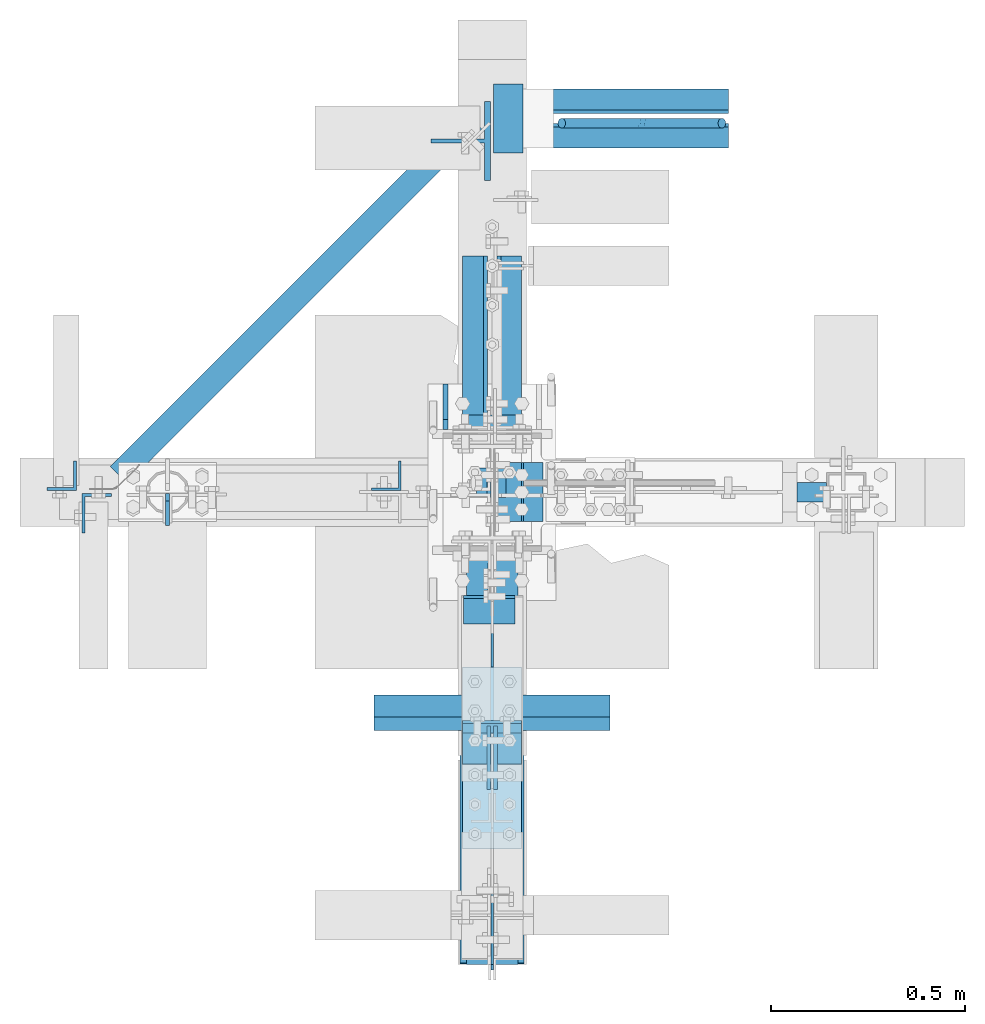
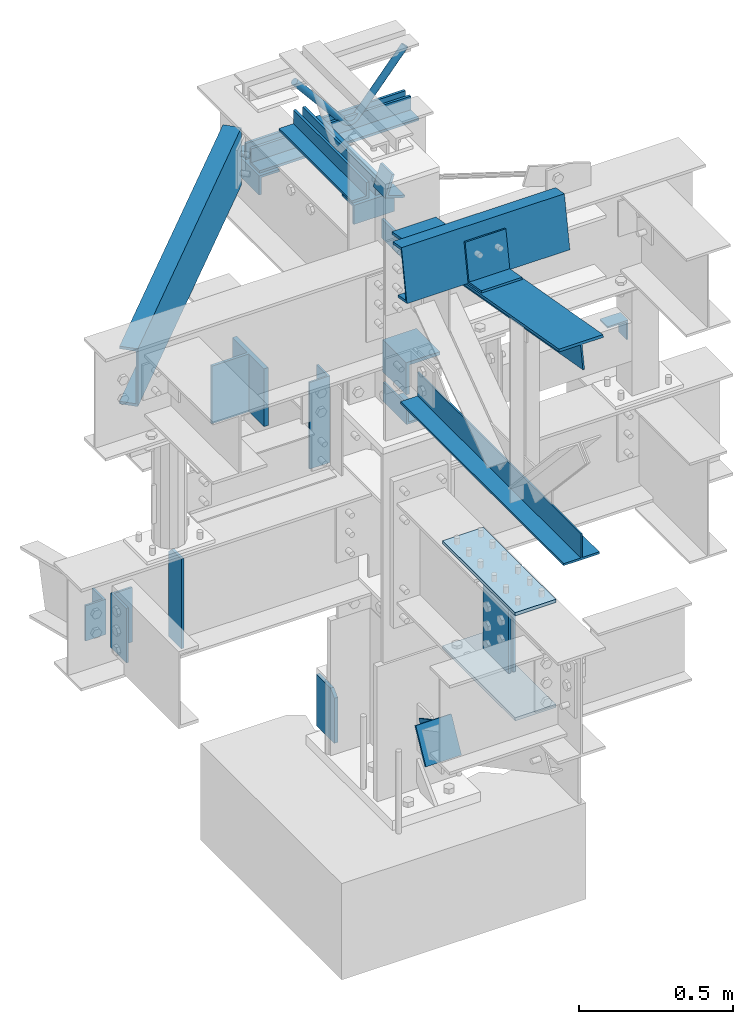
# Not in any storey, part 2 of 8: 19 members, 6 plates, 3 beams, 17 elements without a shape of their own.
"""IFC2X3 building model written with IfcOpenShell, lengths in inches."""

from ifc_helpers import new_model, entity, si_unit, converted_unit, frame, origin_with_axes, place, context, project, spatial, faceted_brep, source, transform, mapped, material, type_object, type_shapes, element, aggregate, save


model = new_model("IFC2X3")

# Units and contexts
model_context = context("Model", 3, precision=1e-05, world=origin_with_axes())
ifc_project = project(units=[converted_unit("LENGTHUNIT", "INCH", entity("IfcLengthMeasure", 25.4), si_unit("LENGTHUNIT", "METRE", prefix="MILLI"), dimensions=[1, 0, 0, 0, 0, 0, 0]), si_unit("PLANEANGLEUNIT", "RADIAN"), si_unit("MASSUNIT", "GRAM", prefix="KILO"), si_unit("TIMEUNIT", "SECOND"), si_unit("AREAUNIT", "SQUARE_METRE"), si_unit("PRESSUREUNIT", "PASCAL"), si_unit("FORCEUNIT", "NEWTON"), si_unit("THERMODYNAMICTEMPERATUREUNIT", "DEGREE_CELSIUS")], contexts=[model_context])

# Site, building
site_placement = place(None, origin_with_axes())
site = spatial("IfcSite", under=ifc_project, at=site_placement, CompositionType="ELEMENT")
building_placement = place(site_placement, origin_with_axes())
building = spatial("IfcBuilding", under=site, at=building_placement, Name="Building", CompositionType="ELEMENT")

# Assembly, members
assembly_1_placement = place(building_placement, frame((0.0, 0.0, 97.0), z_axis=(0.0, 0.0, -1.0), x_axis=(0.0, 1.0, 0.0)))
assembly_1 = element("IfcElementAssembly", 1, at=assembly_1_placement, inside=building, Name="M_40", PredefinedType="NOTDEFINED")
ifc_material_1 = material()
member_type_1 = type_object("IfcMemberType", Name="L2-1/2x2-1/2x3/8", PredefinedType="USERDEFINED", material=ifc_material_1)
shared_shape_1 = source(origin_with_axes(), model_context, "Body", "Brep", [
    faceted_brep([(0.0, 0.0, 0.0), (0.0, -2.5, 0.0), (0.0, -2.5, 0.375), (0.0, -0.375, 0.375), (0.0, -0.375, 2.5), (0.0, 0.0, 2.5), (18.625, 0.0, 2.5), (18.625, -0.375, 2.5), (18.625, -0.375, 0.375), (18.625, -2.5, 0.375), (18.625, -2.5, 0.0), (18.625, 0.0, 0.0)], [[[0, 1, 2, 3, 4, 5]], [[6, 7, 8, 9, 10, 11]], [[0, 11, 10, 1]], [[1, 10, 9, 2]], [[2, 9, 8, 3]], [[3, 8, 7, 4]], [[4, 7, 6, 5]], [[5, 6, 11, 0]]]),
])
type_shapes(member_type_1, [shared_shape_1])
member_1_placement = place(assembly_1_placement, frame((5.375, 0.5, 12.0), z_axis=(0.0, 0.0, -1.0), x_axis=(1.0, 0.0, 0.0)))
member_1 = element("IfcMember", 2, at=member_1_placement, type_object=member_type_1, Name="a33", ObjectType="Member", context=model_context, shape_type="MappedRepresentation", body=[
    mapped(shared_shape_1, transform((0.0, 0.0, 0.0), scale=1.0)),
])
member_type_2 = type_object("IfcMemberType", Name="L2-1/2x2-1/2x3/8", PredefinedType="USERDEFINED", material=ifc_material_1)
shared_shape_2 = source(origin_with_axes(), model_context, "Body", "Brep", [
    faceted_brep([(0.0, 0.375, 0.375), (0.0, 2.5, 0.375), (0.0, 2.5, 0.0), (0.0, 0.0, 0.0), (0.0, 0.0, 2.5), (0.0, 0.375, 2.5), (18.625, 0.375, 2.5), (18.625, 0.0, 2.5), (18.625, 0.0, 0.0), (18.625, 2.5, 0.0), (18.625, 2.5, 0.375), (18.625, 0.375, 0.375)], [[[0, 1, 2, 3, 4, 5]], [[6, 7, 8, 9, 10, 11]], [[0, 11, 10, 1]], [[1, 10, 9, 2]], [[2, 9, 8, 3]], [[3, 8, 7, 4]], [[4, 7, 6, 5]], [[5, 6, 11, 0]]]),
])
type_shapes(member_type_2, [shared_shape_2])
member_2_placement = place(assembly_1_placement, frame((24.0000038146973, -0.5, 12.0), z_axis=(0.0, -1.0, 0.0), x_axis=(-1.0, 0.0, 0.0)))
member_2 = element("IfcMember", 3, at=member_2_placement, type_object=member_type_2, Name="a34", ObjectType="Member", context=model_context, shape_type="MappedRepresentation", body=[
    mapped(shared_shape_2, transform((0.0, 0.0, 0.0), scale=1.0)),
])
aggregate(assembly_1, [member_1, member_2])

assembly_2_placement = place(building_placement, frame((0.0, 38.0, 82.5), z_axis=(0.0, 0.0, -1.0), x_axis=(1.0, 0.0, 0.0)))
assembly_2 = element("IfcElementAssembly", 4, at=assembly_2_placement, inside=building, Name="M_41", PredefinedType="NOTDEFINED")
member_type_3 = type_object("IfcMemberType", Name="L2-1/2x2-1/2x3/8", PredefinedType="USERDEFINED", material=ifc_material_1)
shared_shape_3 = source(origin_with_axes(), model_context, "Body", "Brep", [
    faceted_brep([(0.0, 0.0, 0.0), (0.0, -2.5, 0.0), (0.0, -2.5, 0.375), (0.0, -0.375, 0.375), (0.0, -0.375, 2.5), (0.0, 0.0, 2.5), (23.5, 0.0, 2.5), (23.5, -0.375, 2.5), (23.5, -0.375, 0.375), (23.5, -2.5, 0.375), (23.5, -2.5, 0.0), (23.5, 0.0, 0.0)], [[[0, 1, 2, 3, 4, 5]], [[6, 7, 8, 9, 10, 11]], [[0, 11, 10, 1]], [[1, 10, 9, 2]], [[2, 9, 8, 3]], [[3, 8, 7, 4]], [[4, 7, 6, 5]], [[5, 6, 11, 0]]]),
])
type_shapes(member_type_3, [shared_shape_3])
member_3_placement = place(assembly_2_placement, frame((0.5, 0.5, 12.0), z_axis=(0.0, 0.0, -1.0), x_axis=(1.0, 0.0, 0.0)))
member_3 = element("IfcMember", 5, at=member_3_placement, type_object=member_type_3, Name="a37", ObjectType="Member", context=model_context, shape_type="MappedRepresentation", body=[
    mapped(shared_shape_3, transform((0.0, 0.0, 0.0), scale=1.0)),
])
member_type_4 = type_object("IfcMemberType", Name="L2-1/2x2-1/2x3/8", PredefinedType="USERDEFINED", material=ifc_material_1)
shared_shape_4 = source(origin_with_axes(), model_context, "Body", "Brep", [
    faceted_brep([(0.0, 0.375, 0.375), (0.0, 2.5, 0.375), (0.0, 2.5, 0.0), (0.0, 0.0, 0.0), (0.0, 0.0, 2.5), (0.0, 0.375, 2.5), (23.5, 0.375, 2.5), (23.5, 0.0, 2.5), (23.5, 0.0, 0.0), (23.5, 2.5, 0.0), (23.5, 2.5, 0.375), (23.5, 0.375, 0.375)], [[[0, 1, 2, 3, 4, 5]], [[6, 7, 8, 9, 10, 11]], [[0, 11, 10, 1]], [[1, 10, 9, 2]], [[2, 9, 8, 3]], [[3, 8, 7, 4]], [[4, 7, 6, 5]], [[5, 6, 11, 0]]]),
])
type_shapes(member_type_4, [shared_shape_4])
member_4_placement = place(assembly_2_placement, frame((24.0000038146973, -0.5, 12.0), z_axis=(0.0, -1.0, 0.0), x_axis=(-1.0, 0.0, 0.0)))
member_4 = element("IfcMember", 6, at=member_4_placement, type_object=member_type_4, Name="a38", ObjectType="Member", context=model_context, shape_type="MappedRepresentation", body=[
    mapped(shared_shape_4, transform((0.0, 0.0, 0.0), scale=1.0)),
])

# Assembly, beam
assembly_3_placement = place(building_placement, frame((0.0, -3.0, 80.0), z_axis=(0.0, 0.0, -1.0), x_axis=(0.0, 1.0, 0.0)))
assembly_3 = element("IfcElementAssembly", 7, at=assembly_3_placement, inside=building, Name="2-9", PredefinedType="NOTDEFINED")
beam_type_1 = type_object("IfcBeamType", Name="L3x3x3/8", PredefinedType="USERDEFINED", material=ifc_material_1)
shared_shape_5 = source(origin_with_axes(), model_context, "Body", "Brep", [
    faceted_brep([(0.0, 0.0, 0.0), (0.0, -3.0, 0.0), (0.0, -3.0, 0.375), (0.0, -0.375, 0.375), (0.0, -0.375, 3.0), (0.0, 0.0, 3.0), (6.0, 0.0, 3.0), (6.0, -0.375, 3.0), (6.0, -0.375, 0.375), (6.0, -3.0, 0.375), (6.0, -3.0, 0.0), (6.0, 0.0, 0.0)], [[[0, 1, 2, 3, 4, 5]], [[6, 7, 8, 9, 10, 11]], [[0, 11, 10, 1]], [[1, 10, 9, 2]], [[2, 9, 8, 3]], [[3, 8, 7, 4]], [[4, 7, 6, 5]], [[5, 6, 11, 0]]]),
])
type_shapes(beam_type_1, [shared_shape_5])
beam_1_placement = place(assembly_3_placement, frame((0.0, 0.0, 0.0), z_axis=(0.0, 0.0, -1.0), x_axis=(1.0, 0.0, 0.0)))
beam_1 = element("IfcBeam", 8, at=beam_1_placement, type_object=beam_type_1, Name="a27", ObjectType="Member", context=model_context, shape_type="MappedRepresentation", body=[
    mapped(shared_shape_5, transform((0.0, 0.0, 0.0), scale=1.0)),
])
aggregate(assembly_3, [beam_1])

# Assembly, member
assembly_4_placement = place(building_placement, frame((0.0, 0.0, 21.0), z_axis=(0.0, -1.0, 0.0), x_axis=(0.0, 0.0, 1.0)))
assembly_4 = element("IfcElementAssembly", 9, at=assembly_4_placement, inside=building, Name="1-2", PredefinedType="NOTDEFINED")
member_type_5 = type_object("IfcMemberType", Name="L3x3x5/16", PredefinedType="USERDEFINED", material=ifc_material_1)
shared_shape_6 = source(origin_with_axes(), model_context, "Body", "Brep", [
    faceted_brep([(0.0, 0.0, 0.0), (0.0, -3.0, 0.0), (0.0, -3.0, 0.3125), (0.0, -0.3125, 0.3125), (0.0, -0.3125, 3.0), (0.0, 0.0, 3.0), (6.0, 0.0, 3.0), (6.0, -0.3125, 3.0), (6.0, -0.3125, 0.3125), (6.0, -3.0, 0.3125), (6.0, -3.0, 0.0), (6.0, 0.0, 0.0)], [[[0, 1, 2, 3, 4, 5]], [[6, 7, 8, 9, 10, 11]], [[0, 11, 10, 1]], [[1, 10, 9, 2]], [[2, 9, 8, 3]], [[3, 8, 7, 4]], [[4, 7, 6, 5]], [[5, 6, 11, 0]]]),
])
type_shapes(member_type_5, [shared_shape_6])
member_5_placement = place(assembly_4_placement, frame((33.5, -0.207499995827675, -3.0), z_axis=(0.0, -1.0, 0.0), x_axis=(0.0, 0.0, 1.0)))
member_5 = element("IfcMember", 10, at=member_5_placement, type_object=member_type_5, Name="a29", ObjectType="Column", context=model_context, shape_type="MappedRepresentation", body=[
    mapped(shared_shape_6, transform((0.0, 0.0, 0.0), scale=1.0)),
])
aggregate(assembly_4, [member_5])

# Assembly, members
assembly_5_placement = place(building_placement, frame((0.0, 0.0, 54.5), z_axis=(0.0, -1.0, 0.0), x_axis=(0.0, 0.0, 1.0)))
assembly_5 = element("IfcElementAssembly", 11, at=assembly_5_placement, inside=building, Name="1-3", PredefinedType="NOTDEFINED")
member_type_6 = type_object("IfcMemberType", Name="L3-1/2x3x3/8", PredefinedType="USERDEFINED", material=ifc_material_1)
shared_shape_7 = source(origin_with_axes(), model_context, "Body", "Brep", [
    faceted_brep([(0.0, 0.375, 0.375), (0.0, 3.0, 0.375), (0.0, 3.0, 0.0), (0.0, 0.0, 0.0), (0.0, 0.0, 3.5), (0.0, 0.375, 3.5), (3.0, 0.375, 3.5), (3.0, 0.0, 3.5), (3.0, 0.0, 0.0), (3.0, 3.0, 0.0), (3.0, 3.0, 0.375), (3.0, 0.375, 0.375)], [[[0, 1, 2, 3, 4, 5]], [[6, 7, 8, 9, 10, 11]], [[0, 11, 10, 1]], [[1, 10, 9, 2]], [[2, 9, 8, 3]], [[3, 8, 7, 4]], [[4, 7, 6, 5]], [[5, 6, 11, 0]]]),
])
type_shapes(member_type_6, [shared_shape_7])
member_6_placement = place(assembly_5_placement, frame((34.3969296478214, 1.56886904721182, -2.43749999809271), z_axis=(0.952395799643279, -0.304864299028012, 0.0), x_axis=(0.0, 0.0, 1.0)))
member_6 = element("IfcMember", 12, at=member_6_placement, type_object=member_type_6, Name="a24", ObjectType="Column", context=model_context, shape_type="MappedRepresentation", body=[
    mapped(shared_shape_7, transform((0.0, 0.0, 0.0), scale=1.0)),
])
member_type_7 = type_object("IfcMemberType", Name="L5x5x1/2", PredefinedType="USERDEFINED", material=ifc_material_1)
shared_shape_8 = source(origin_with_axes(), model_context, "Body", "Brep", [
    faceted_brep([(0.0, 0.0, 0.0), (0.0, -5.0, 0.0), (0.0, -5.0, 0.5), (0.0, -0.5, 0.5), (0.0, -0.5, 5.0), (0.0, 0.0, 5.0), (6.0, 0.0, 5.0), (6.0, -0.5, 5.0), (6.0, -0.5, 0.5), (6.0, -5.0, 0.5), (6.0, -5.0, 0.0), (6.0, 0.0, 0.0)], [[[0, 1, 2, 3, 4, 5]], [[6, 7, 8, 9, 10, 11]], [[0, 11, 10, 1]], [[1, 10, 9, 2]], [[2, 9, 8, 3]], [[3, 8, 7, 4]], [[4, 7, 6, 5]], [[5, 6, 11, 0]]]),
])
type_shapes(member_type_7, [shared_shape_8])
member_7_placement = place(assembly_5_placement, frame((9.64000034332275, -0.144999995827675, 3.0), z_axis=(0.0, -1.0, 0.0), x_axis=(0.0, 0.0, -1.0)))
member_7 = element("IfcMember", 13, at=member_7_placement, type_object=member_type_7, Name="a28", ObjectType="Column", context=model_context, shape_type="MappedRepresentation", body=[
    mapped(shared_shape_8, transform((0.0, 0.0, 0.0), scale=1.0)),
])
member_type_8 = type_object("IfcMemberType", Name="L3x3x3/8", PredefinedType="USERDEFINED", material=ifc_material_1)
shared_shape_9 = source(origin_with_axes(), model_context, "Body", "Brep", [
    faceted_brep([(0.0, 0.0, 0.0), (0.0, -3.0, 0.0), (0.0, -3.0, 0.375), (0.0, -0.375, 0.375), (0.0, -0.375, 3.0), (0.0, 0.0, 3.0), (6.0, 0.0, 3.0), (6.0, -0.375, 3.0), (6.0, -0.375, 0.375), (6.0, -3.0, 0.375), (6.0, -3.0, 0.0), (6.0, 0.0, 0.0)], [[[0, 1, 2, 3, 4, 5]], [[6, 7, 8, 9, 10, 11]], [[0, 11, 10, 1]], [[1, 10, 9, 2]], [[2, 9, 8, 3]], [[3, 8, 7, 4]], [[4, 7, 6, 5]], [[5, 6, 11, 0]]]),
])
type_shapes(member_type_8, [shared_shape_9])
member_8_placement = place(assembly_5_placement, frame((30.5, -3.0, -4.86499977111816), z_axis=(0.0, 0.0, -1.0), x_axis=(0.0, 1.0, 0.0)))
member_8 = element("IfcMember", 14, at=member_8_placement, type_object=member_type_8, Name="a27", ObjectType="Column", context=model_context, shape_type="MappedRepresentation", body=[
    mapped(shared_shape_9, transform((0.0, 0.0, 0.0), scale=1.0)),
])
aggregate(assembly_5, [member_6, member_7, member_8])

# Assembly, member
assembly_6_placement = place(building_placement, frame((0.0, 0.0, 46.0), z_axis=(0.0, 0.0, 1.0), x_axis=(0.0, 1.0, 0.0)))
assembly_6 = element("IfcElementAssembly", 15, at=assembly_6_placement, inside=building, Name="2-3", PredefinedType="NOTDEFINED")
ifc_material_2 = material()
member_type_9 = type_object("IfcMemberType", Name="WT6x25", PredefinedType="USERDEFINED", material=ifc_material_2)
shared_shape_10 = source(origin_with_axes(), model_context, "Body", "Brep", [
    faceted_brep([(0.0, -0.185, -6.095), (0.0, -0.185, -0.64), (0.0, -4.04, -0.64), (0.0, -4.04, 0.0), (0.0, 4.04, 0.0), (0.0, 4.04, -0.64), (0.0, 0.185, -0.64), (0.0, 0.185, -6.095), (9.0, 0.185, -6.095), (9.0, 0.185, -0.64), (9.0, 4.04, -0.64), (9.0, 4.04, 0.0), (9.0, -4.04, 0.0), (9.0, -4.04, -0.64), (9.0, -0.185, -0.64), (9.0, -0.185, -6.095)], [[[0, 1, 2, 3, 4, 5, 6, 7]], [[8, 9, 10, 11, 12, 13, 14, 15]], [[0, 15, 14, 1]], [[1, 14, 13, 2]], [[2, 13, 12, 3]], [[3, 12, 11, 4]], [[4, 11, 10, 5]], [[5, 10, 9, 6]], [[6, 9, 8, 7]], [[7, 8, 15, 0]]]),
])
type_shapes(member_type_9, [shared_shape_10])
member_9_placement = place(assembly_6_placement, frame((35.6999999880791, 0.14750000834465, -12.5), z_axis=(0.0, -1.0, 0.0), x_axis=(0.0, 0.0, 1.0)))
member_9 = element("IfcMember", 16, at=member_9_placement, type_object=member_type_9, Name="wt5", ObjectType="Beam", context=model_context, shape_type="MappedRepresentation", body=[
    mapped(shared_shape_10, transform((0.0, 0.0, 0.0), scale=1.0)),
])
aggregate(assembly_6, [member_9])

assembly_7_placement = place(building_placement, frame((0.0, 0.0, 46.0), z_axis=(0.0, 0.0, 1.0), x_axis=(-1.0, 0.0, 0.0)))
assembly_7 = element("IfcElementAssembly", 17, at=assembly_7_placement, inside=building, Name="2-4", PredefinedType="NOTDEFINED")
member_type_10 = type_object("IfcMemberType", Name="L4x3x5/16", PredefinedType="USERDEFINED", material=ifc_material_1)
shared_shape_11 = source(origin_with_axes(), model_context, "Body", "Brep", [
    faceted_brep([(0.0, 0.3125, 0.3125), (0.0, 3.0, 0.3125), (0.0, 3.0, 0.0), (0.0, 0.0, 0.0), (0.0, 0.0, 4.0), (0.0, 0.3125, 4.0), (8.5, 0.3125, 4.0), (8.5, 0.0, 4.0), (8.5, 0.0, 0.0), (8.5, 3.0, 0.0), (8.5, 3.0, 0.3125), (8.5, 0.3125, 0.3125)], [[[0, 1, 2, 3, 4, 5]], [[6, 7, 8, 9, 10, 11]], [[0, 11, 10, 1]], [[1, 10, 9, 2]], [[2, 9, 8, 3]], [[3, 8, 7, 4]], [[4, 7, 6, 5]], [[5, 6, 11, 0]]]),
])
type_shapes(member_type_10, [shared_shape_11])
member_10_placement = place(assembly_7_placement, frame((41.7179999947548, 0.14750000834465, -4.75), z_axis=(0.0, 1.0, 0.0), x_axis=(0.0, 0.0, -1.0)))
member_10 = element("IfcMember", 18, at=member_10_placement, type_object=member_type_10, Name="a1", ObjectType="Beam", context=model_context, shape_type="MappedRepresentation", body=[
    mapped(shared_shape_11, transform((0.0, 0.0, 0.0), scale=1.0)),
])

assembly_8_placement = place(building_placement, frame((-9.25, 0.0, 50.0), z_axis=(-1.0, 0.0, 0.0), x_axis=(0.0, 0.0, 1.0)))
assembly_8 = element("IfcElementAssembly", 19, at=assembly_8_placement, inside=building, Name="4-5", PredefinedType="NOTDEFINED")
member_type_11 = type_object("IfcMemberType", Name="L3x3x1/4", PredefinedType="USERDEFINED", material=ifc_material_1)
shared_shape_12 = source(origin_with_axes(), model_context, "Body", "Brep", [
    faceted_brep([(0.0, 0.25, 0.25), (0.0, 3.0, 0.25), (0.0, 3.0, 0.0), (0.0, 0.0, 0.0), (0.0, 0.0, 3.0), (0.0, 0.25, 3.0), (13.5, 0.25, 3.0), (13.5, 0.0, 3.0), (13.5, 0.0, 0.0), (13.5, 3.0, 0.0), (13.5, 3.0, 0.25), (13.5, 0.25, 0.25)], [[[0, 1, 2, 3, 4, 5]], [[6, 7, 8, 9, 10, 11]], [[0, 11, 10, 1]], [[1, 10, 9, 2]], [[2, 9, 8, 3]], [[3, 8, 7, 4]], [[4, 7, 6, 5]], [[5, 6, 11, 0]]]),
])
type_shapes(member_type_11, [shared_shape_12])
member_11_placement = place(assembly_8_placement, frame((13.5, 0.156249999999994, 0.0), z_axis=(0.0, 1.0, 0.0), x_axis=(-1.0, 0.0, 0.0)))
member_11 = element("IfcMember", 20, at=member_11_placement, type_object=member_type_11, Name="a36", ObjectType="Column", context=model_context, shape_type="MappedRepresentation", body=[
    mapped(shared_shape_12, transform((0.0, 0.0, 0.0), scale=1.0)),
])
aggregate(assembly_8, [member_11])

assembly_9_placement = place(building_placement, frame((36.0, 0.0, 46.0), z_axis=(-1.0, 0.0, 0.0), x_axis=(0.0, 0.0, 1.0)))
assembly_9 = element("IfcElementAssembly", 21, at=assembly_9_placement, inside=building, Name="4-1", PredefinedType="NOTDEFINED")
member_type_12 = type_object("IfcMemberType", Name="L3x3x1/4", PredefinedType="USERDEFINED", material=ifc_material_1)
shared_shape_13 = source(origin_with_axes(), model_context, "Body", "Brep", [
    faceted_brep([(0.0, 0.0, 0.0), (0.0, -3.0, 0.0), (0.0, -3.0, 0.25), (0.0, -0.25, 0.25), (0.0, -0.25, 3.0), (0.0, 0.0, 3.0), (2.0, 0.0, 3.0), (2.0, -0.25, 3.0), (2.0, -0.25, 0.25), (2.0, -3.0, 0.25), (2.0, -3.0, 0.0), (2.0, 0.0, 0.0)], [[[0, 1, 2, 3, 4, 5]], [[6, 7, 8, 9, 10, 11]], [[0, 11, 10, 1]], [[1, 10, 9, 2]], [[2, 9, 8, 3]], [[3, 8, 7, 4]], [[4, 7, 6, 5]], [[5, 6, 11, 0]]]),
])
type_shapes(member_type_12, [shared_shape_13])
member_12_placement = place(assembly_9_placement, frame((11.75, 1.0, 2.0), z_axis=(0.0, 0.0, 1.0), x_axis=(0.0, -1.0, 0.0)))
member_12 = element("IfcMember", 22, at=member_12_placement, type_object=member_type_12, Name="a11", ObjectType="Column", context=model_context, shape_type="MappedRepresentation", body=[
    mapped(shared_shape_13, transform((0.0, 0.0, 0.0), scale=1.0)),
])
aggregate(assembly_9, [member_12])

assembly_10_placement = place(building_placement, frame((-42.0, 0.0, 43.0), z_axis=(0.0, 0.242535628120103, 0.970142499374389), x_axis=(0.0, 0.970142499374388, -0.242535628120103)))
assembly_10 = element("IfcElementAssembly", 23, at=assembly_10_placement, inside=building, Name="3-8", PredefinedType="NOTDEFINED")
member_type_13 = type_object("IfcMemberType", Name="L3x3x5/16", PredefinedType="USERDEFINED", material=ifc_material_1)
shared_shape_14 = source(origin_with_axes(), model_context, "Body", "Brep", [
    faceted_brep([(0.0, 0.0, 0.0), (0.0, -3.0, 0.0), (0.0, -3.0, 0.3125), (0.0, -0.3125, 0.3125), (0.0, -0.3125, 3.0), (0.0, 0.0, 3.0), (5.5, 0.0, 3.0), (5.5, -0.3125, 3.0), (5.5, -0.3125, 0.3125), (5.5, -3.0, 0.3125), (5.5, -3.0, 0.0), (5.5, 0.0, 0.0)], [[[0, 1, 2, 3, 4, 5]], [[6, 7, 8, 9, 10, 11]], [[0, 11, 10, 1]], [[1, 10, 9, 2]], [[2, 9, 8, 3]], [[3, 8, 7, 4]], [[4, 7, 6, 5]], [[5, 6, 11, 0]]]),
])
type_shapes(member_type_13, [shared_shape_14])
member_13_placement = place(assembly_10_placement, frame((0.848874774117084, 0.239999994635582, -2.62241641770861), z_axis=(0.0, 1.0, 0.0), x_axis=(0.242535628120103, 0.0, -0.970142499374389)))
member_13 = element("IfcMember", 24, at=member_13_placement, type_object=member_type_13, Name="a2", ObjectType="Beam", context=model_context, shape_type="MappedRepresentation", body=[
    mapped(shared_shape_14, transform((0.0, 0.0, 0.0), scale=1.0)),
])
aggregate(assembly_10, [member_13])

# Assembly, beam
assembly_11_placement = place(building_placement, frame((-38.0, 0.0, 77.0), z_axis=(0.0, 0.0, 1.0), x_axis=(0.707106765732237, 0.707106796640858, 0.0)))
assembly_11 = element("IfcElementAssembly", 25, at=assembly_11_placement, inside=building, Name="3-12", PredefinedType="NOTDEFINED")
ifc_material_3 = material()
beam_type_2 = type_object("IfcBeamType", Name="C9x13.4", PredefinedType="BEAM", material=ifc_material_3)
shared_shape_15 = source(origin_with_axes(), model_context, "Body", "Brep", [
    faceted_brep([(0.0, 0.233, -8.587), (0.0, 2.433, -8.587), (0.0, 2.433, -9.0), (0.0, 0.0, -9.0), (0.0, 0.0, 0.0), (0.0, 2.433, 0.0), (0.0, 2.433, -0.413), (0.0, 0.233, -0.413), (50.9901, 0.233, -0.413), (50.9901, 2.433, -0.413), (50.9901, 2.433, 0.0), (50.9901, 0.0, 0.0), (50.9901, 0.0, -9.0), (50.9901, 2.433, -9.0), (50.9901, 2.433, -8.587), (50.9901, 0.233, -8.587)], [[[0, 1, 2, 3, 4, 5, 6, 7]], [[8, 9, 10, 11, 12, 13, 14, 15]], [[0, 15, 14, 1]], [[1, 14, 13, 2]], [[2, 13, 12, 3]], [[3, 12, 11, 4]], [[4, 11, 10, 5]], [[5, 10, 9, 6]], [[6, 9, 8, 7]], [[7, 8, 15, 0]]]),
])
type_shapes(beam_type_2, [shared_shape_15])
beam_2_placement = place(assembly_11_placement, frame((1.25, 0.0, 0.0), z_axis=(0.0, 0.0, 1.0), x_axis=(1.0, 0.0, 0.0)))
beam_2 = element("IfcBeam", 26, at=beam_2_placement, type_object=beam_type_2, Name="c5", ObjectType="Beam", context=model_context, shape_type="MappedRepresentation", body=[
    mapped(shared_shape_15, transform((0.0, 0.0, 0.0), scale=1.0)),
])
aggregate(assembly_11, [beam_2])

# Assembly, member
assembly_12_placement = place(building_placement, frame((0.0, 0.0, 80.0), z_axis=(0.0, 0.0, 1.0), x_axis=(0.0, 1.0, 0.0)))
assembly_12 = element("IfcElementAssembly", 27, at=assembly_12_placement, inside=building, Name="2-6", PredefinedType="NOTDEFINED")
member_type_14 = type_object("IfcMemberType", Name="L3x3x3/8", PredefinedType="USERDEFINED", material=ifc_material_1)
shared_shape_16 = source(origin_with_axes(), model_context, "Body", "Brep", [
    faceted_brep([(0.0, 0.0, 0.0), (0.0, -3.0, 0.0), (0.0, -3.0, 0.375), (0.0, -0.375, 0.375), (0.0, -0.375, 3.0), (0.0, 0.0, 3.0), (7.0, 0.0, 3.0), (7.0, -0.375, 3.0), (7.0, -0.375, 0.375), (7.0, -3.0, 0.375), (7.0, -3.0, 0.0), (7.0, 0.0, 0.0)], [[[0, 1, 2, 3, 4, 5]], [[6, 7, 8, 9, 10, 11]], [[0, 11, 10, 1]], [[1, 10, 9, 2]], [[2, 9, 8, 3]], [[3, 8, 7, 4]], [[4, 7, 6, 5]], [[5, 6, 11, 0]]]),
])
type_shapes(member_type_14, [shared_shape_16])
member_14_placement = place(assembly_12_placement, frame((34.5, -0.14750000834465, -9.5), z_axis=(0.0, -1.0, 0.0), x_axis=(1.0, 0.0, 0.0)))
member_14 = element("IfcMember", 28, at=member_14_placement, type_object=member_type_14, Name="a35", ObjectType="Beam", context=model_context, shape_type="MappedRepresentation", body=[
    mapped(shared_shape_16, transform((0.0, 0.0, 0.0), scale=1.0)),
])
aggregate(assembly_12, [member_14])

assembly_13_placement = place(building_placement, frame((-0.302501678466797, -6.35499954223631, 7.97817420959473), z_axis=(0.0, 0.470283939984076, 0.882515164624979), x_axis=(0.0, -0.882515164624978, 0.470283939984076)))
assembly_13 = element("IfcElementAssembly", 29, at=assembly_13_placement, inside=building, Name="4-6", PredefinedType="NOTDEFINED")
member_type_15 = type_object("IfcMemberType", Name="WT4x9", PredefinedType="BRACE", material=ifc_material_2)
shared_shape_17 = source(origin_with_axes(), model_context, "Body", "Brep", [
    faceted_brep([(0.0, -0.115, -4.07), (0.0, -0.115, -0.33), (0.0, -2.625, -0.33), (0.0, -2.625, 0.0), (0.0, 2.625, 0.0), (0.0, 2.625, -0.33), (0.0, 0.115, -0.33), (0.0, 0.115, -4.07), (5.5, 0.115, -4.07), (5.5, 0.115, -0.33), (5.5, 2.625, -0.33), (5.5, 2.625, 0.0), (5.5, -2.625, 0.0), (5.5, -2.625, -0.33), (5.5, -0.115, -0.33), (5.5, -0.115, -4.07)], [[[0, 1, 2, 3, 4, 5, 6, 7]], [[8, 9, 10, 11, 12, 13, 14, 15]], [[0, 15, 14, 1]], [[1, 14, 13, 2]], [[2, 13, 12, 3]], [[3, 12, 11, 4]], [[4, 11, 10, 5]], [[5, 10, 9, 6]], [[6, 9, 8, 7]], [[7, 8, 15, 0]]]),
])
type_shapes(member_type_15, [shared_shape_17])
member_15_placement = place(assembly_13_placement, frame((6.49234243351773, 0.0, 2.75002784669811), z_axis=(1.0, 0.0, 0.0), x_axis=(0.0, 0.0, -1.0)))
member_15 = element("IfcMember", 30, at=member_15_placement, type_object=member_type_15, Name="wt1", ObjectType="Vertical brace", context=model_context, shape_type="MappedRepresentation", body=[
    mapped(shared_shape_17, transform((0.0, 0.0, 0.0), scale=1.0)),
])
aggregate(assembly_13, [member_15])

# Assembly, members
assembly_14_placement = place(building_placement, frame((0.0, -47.9999999999999, 94.0), z_axis=(0.0, 0.17437043319647, 0.984680126755321), x_axis=(0.0, 0.98468012675532, -0.17437043319647)))
assembly_14 = element("IfcElementAssembly", 31, at=assembly_14_placement, inside=building, Name="4-8", PredefinedType="NOTDEFINED")
member_type_16 = type_object("IfcMemberType", Name="L6x3-1/2x5/16", PredefinedType="USERDEFINED", material=ifc_material_1)
shared_shape_18 = source(origin_with_axes(), model_context, "Body", "Brep", [
    faceted_brep([(0.0, 0.0, 0.0), (0.0, -3.5, 0.0), (0.0, -3.5, 0.3125), (0.0, -0.3125, 0.3125), (0.0, -0.3125, 6.0), (0.0, 0.0, 6.0), (6.0, 0.0, 6.0), (6.0, -0.3125, 6.0), (6.0, -0.3125, 0.3125), (6.0, -3.5, 0.3125), (6.0, -3.5, 0.0), (6.0, 0.0, 0.0)], [[[0, 1, 2, 3, 4, 5]], [[6, 7, 8, 9, 10, 11]], [[0, 11, 10, 1]], [[1, 10, 9, 2]], [[2, 9, 8, 3]], [[3, 8, 7, 4]], [[4, 7, 6, 5]], [[5, 6, 11, 0]]]),
])
type_shapes(member_type_16, [shared_shape_18])
member_16_placement = place(assembly_14_placement, frame((24.0000007250116, 3.0, 0.687500208160415), z_axis=(0.0, 0.0, 1.0), x_axis=(0.0, -1.0, 0.0)))
member_16 = element("IfcMember", 32, at=member_16_placement, type_object=member_type_16, Name="a25", ObjectType="Beam", context=model_context, shape_type="MappedRepresentation", body=[
    mapped(shared_shape_18, transform((0.0, 0.0, 0.0), scale=1.0)),
])
member_type_17 = type_object("IfcMemberType", Name="WT4x9", PredefinedType="USERDEFINED", material=ifc_material_2)
shared_shape_19 = source(origin_with_axes(), model_context, "Body", "Brep", [
    faceted_brep([(0.0, -0.115, -4.07), (0.0, -0.115, -0.33), (0.0, -2.625, -0.33), (0.0, -2.625, 0.0), (0.0, 2.625, 0.0), (0.0, 2.625, -0.33), (0.0, 0.115, -0.33), (0.0, 0.115, -4.07), (41.625, 0.115, -4.07), (41.625, 0.115, -0.33), (41.625, 2.625, -0.33), (41.625, 2.625, 0.0), (41.625, -2.625, 0.0), (41.625, -2.625, -0.33), (41.625, -0.115, -0.33), (41.625, -0.115, -4.07)], [[[0, 1, 2, 3, 4, 5, 6, 7]], [[8, 9, 10, 11, 12, 13, 14, 15]], [[0, 15, 14, 1]], [[1, 14, 13, 2]], [[2, 13, 12, 3]], [[3, 12, 11, 4]], [[4, 11, 10, 5]], [[5, 10, 9, 6]], [[6, 9, 8, 7]], [[7, 8, 15, 0]]]),
])
type_shapes(member_type_17, [shared_shape_19])
member_17_placement = place(assembly_14_placement, frame((5.78691875170775, 0.0, -32.6790717066922), z_axis=(0.17437043319647, 0.0, -0.984680126755321), x_axis=(0.98468012675532, 0.0, 0.17437043319647)))
member_17 = element("IfcMember", 33, at=member_17_placement, type_object=member_type_17, Name="wt2", ObjectType="Beam", context=model_context, shape_type="MappedRepresentation", body=[
    mapped(shared_shape_19, transform((0.0, 0.0, 0.0), scale=1.0)),
])
member_type_18 = type_object("IfcMemberType", Name="WT4x12", PredefinedType="USERDEFINED", material=ifc_material_2)
shared_shape_20 = source(origin_with_axes(), model_context, "Body", "Brep", [
    faceted_brep([(0.0, -3.248, 0.0), (0.0, 3.248, 0.0), (0.0, 3.248, -0.4), (0.0, -3.248, -0.4), (43.309, 3.248, 0.0), (43.38, 3.248, -0.4), (43.309, -3.248, 0.0), (43.38, -3.248, -0.4), (0.0, -0.123, -0.4), (0.0, 0.123, -0.4), (0.0, 0.123, -3.965), (0.0, -0.123, -3.965), (43.38, 0.123, -0.4), (44.0114, 0.123, -3.965), (43.38, -0.123, -0.4), (44.0114, -0.123, -3.965)], [[[0, 1, 2, 3]], [[1, 4, 5, 2]], [[4, 6, 7, 5]], [[6, 0, 3, 7]], [[6, 4, 1, 0]], [[3, 2, 5, 7]], [[8, 9, 10, 11]], [[9, 12, 13, 10]], [[12, 14, 15, 13]], [[14, 8, 11, 15]], [[14, 12, 9, 8]], [[11, 10, 13, 15]]]),
])
type_shapes(member_type_18, [shared_shape_20])
member_18_placement = place(assembly_14_placement, frame((0.0, 0.0, 0.687500208160444), z_axis=(0.0, 0.0, 1.0), x_axis=(1.0, 0.0, 0.0)))
member_18 = element("IfcMember", 34, at=member_18_placement, type_object=member_type_18, Name="wt4", ObjectType="Beam", context=model_context, shape_type="MappedRepresentation", body=[
    mapped(shared_shape_20, transform((0.0, 0.0, 0.0), scale=1.0)),
])
aggregate(assembly_14, [member_16, member_17, member_18])

# Assembly, beam
assembly_15_placement = place(building_placement, frame((-12.0, -24.2477970123291, 90.4920806884765), z_axis=(0.0, -0.174370009636802, -0.984680201760582), x_axis=(1.0, 0.0, 0.0)))
assembly_15 = element("IfcElementAssembly", 35, at=assembly_15_placement, inside=building, Name="4-9", PredefinedType="NOTDEFINED")
beam_type_3 = type_object("IfcBeamType", Name="C8x11.5", PredefinedType="BEAM", material=ifc_material_3)
shared_shape_21 = source(origin_with_axes(), model_context, "Body", "Brep", [
    faceted_brep([(0.0, 0.0, -8.0), (0.0, -2.26, -8.0), (0.0, -2.26, -7.61), (0.0, -0.22, -7.61), (0.0, -0.22, -0.39), (0.0, -2.26, -0.39), (0.0, -2.26, 0.0), (0.0, 0.0, 0.0), (24.0, 0.0, 0.0), (24.0, -2.26, 0.0), (24.0, -2.26, -0.39), (24.0, -0.22, -0.39), (24.0, -0.22, -7.61), (24.0, -2.26, -7.61), (24.0, -2.26, -8.0), (24.0, 0.0, -8.0)], [[[0, 1, 2, 3, 4, 5, 6, 7]], [[8, 9, 10, 11, 12, 13, 14, 15]], [[0, 15, 14, 1]], [[1, 14, 13, 2]], [[2, 13, 12, 3]], [[3, 12, 11, 4]], [[4, 11, 10, 5]], [[5, 10, 9, 6]], [[6, 9, 8, 7]], [[7, 8, 15, 0]]]),
])
type_shapes(beam_type_3, [shared_shape_21])
beam_3_placement = place(assembly_15_placement, origin_with_axes())
beam_3 = element("IfcBeam", 36, at=beam_3_placement, type_object=beam_type_3, Name="c2", ObjectType="Beam", context=model_context, shape_type="MappedRepresentation", body=[
    mapped(shared_shape_21, transform((0.0, 0.0, 0.0), scale=1.0)),
])
aggregate(assembly_15, [beam_3])

# Member
member_19_placement = place(assembly_2_placement, frame((23.4185070188086, 0.497068971505183, 1.55131149292049), z_axis=(0.0, 1.0, 0.0), x_axis=(0.642285189490803, 0.0, 0.766465743109738)))
cartesian_point = entity("IfcCartesianPoint", [0.0, 0.0, 0.0])
ifc_direction = entity("IfcDirection", [0.0, 0.0, 1.0])
member_19 = element("IfcMember", 37, at=member_19_placement, Name="rb2", ObjectType="Member", context=model_context, shape_type="SweptSolid", body=[
    entity("IfcSurfaceCurveSweptAreaSolid", entity("IfcCircleProfileDef", "AREA", None, entity("IfcAxis2Placement2D", entity("IfcCartesianPoint", [0.0, 0.0]), entity("IfcDirection", [1.0, 0.0])), 0.5), entity("IfcAxis2Placement3D", cartesian_point, ifc_direction, entity("IfcDirection", [1.0, 0.0, 0.0])), entity("IfcPolyline", [entity("IfcCartesianPoint", [-0.0454, -0.05412]), entity("IfcCartesianPoint", [1.9215, -11.20844]), entity("IfcCartesianPoint", [1.9183, -11.61735]), entity("IfcCartesianPoint", [1.7879, -11.96562]), entity("IfcCartesianPoint", [1.5227, -12.27681]), entity("IfcCartesianPoint", [1.199, -12.45983]), entity("IfcCartesianPoint", [0.7957, -12.52769]), entity("IfcCartesianPoint", [-10.4979, -12.52762])]), 0.0, 1.0, entity("IfcPlane", entity("IfcAxis2Placement3D", cartesian_point, entity("IfcDirection", [0.0, 1.0, 0.0]), ifc_direction))),
])

aggregate(assembly_2, [member_19, member_3, member_4])

# Assembly, plate
assembly_16_placement = place(building_placement, frame((0.0, 0.0, -1.5), z_axis=(0.0, -1.0, 0.0), x_axis=(0.0, 0.0, 1.0)))
assembly_16 = element("IfcElementAssembly", 38, at=assembly_16_placement, inside=building, Name="1-1", PredefinedType="NOTDEFINED")
ifc_material_4 = material()
plate_type_1 = type_object("IfcPlateType", Name="Plate (Complex)", PredefinedType="SHEET", material=ifc_material_4)
shared_shape_22 = source(origin_with_axes(), model_context, "Body", "Brep", [
    faceted_brep([(-0.25, 0.0, -8.0), (-0.25, -3.625, -8.0), (-0.25, -4.625, -7.0), (-0.25, -4.625, 0.0), (-0.25, 0.0, 0.0), (0.25, 0.0, 0.0), (0.25, -4.625, 0.0), (0.25, -4.625, -7.0), (0.25, -3.625, -8.0), (0.25, 0.0, -8.0)], [[[0, 1, 2, 3, 4]], [[5, 6, 7, 8, 9]], [[9, 8, 1, 0]], [[8, 7, 2, 1]], [[7, 6, 3, 2]], [[6, 5, 4, 3]], [[5, 9, 0, 4]]]),
])
type_shapes(plate_type_1, [shared_shape_22])
plate_1_placement = place(assembly_16_placement, frame((2.5, 4.75, -10.9999995231628), z_axis=(-1.0, 0.0, 0.0), x_axis=(0.0, 1.0, 0.0)))
plate_1 = element("IfcPlate", 39, at=plate_1_placement, type_object=plate_type_1, Name="p21", ObjectType="Column", context=model_context, shape_type="MappedRepresentation", body=[
    mapped(shared_shape_22, transform((0.0, 0.0, 0.0), scale=1.0)),
])
aggregate(assembly_16, [plate_1])

# Plate
plate_type_2 = type_object("IfcPlateType", Name="Plate (Complex)", PredefinedType="SHEET", material=ifc_material_4)
shared_shape_23 = source(origin_with_axes(), model_context, "Body", "Brep", [
    faceted_brep([(-0.1875, 0.0, -14.0), (-0.1875, -3.25, -14.0), (-0.1875, -3.25, 0.0), (-0.1875, -0.75, 0.0), (-0.1875, 0.0, -0.75), (0.1875, 0.0, -0.75), (0.1875, -0.75, 0.0), (0.1875, -3.25, 0.0), (0.1875, -3.25, -14.0), (0.1875, 0.0, -14.0)], [[[0, 1, 2, 3, 4]], [[5, 6, 7, 8, 9]], [[9, 8, 1, 0]], [[8, 7, 2, 1]], [[7, 6, 3, 2]], [[6, 5, 4, 3]], [[5, 9, 0, 4]]]),
])
type_shapes(plate_type_2, [shared_shape_23])
plate_2_placement = place(assembly_7_placement, frame((33.0, 0.14750000834465, -0.492500007152557), z_axis=(0.0, 0.0, 1.0), x_axis=(-1.0, 0.0, 0.0)))
plate_2 = element("IfcPlate", 40, at=plate_2_placement, type_object=plate_type_2, Name="p4", ObjectType="Beam", context=model_context, shape_type="MappedRepresentation", body=[
    mapped(shared_shape_23, transform((0.0, 0.0, 0.0), scale=1.0)),
])

aggregate(assembly_7, [plate_2, member_10])

# Assembly, plates
assembly_17_placement = place(building_placement, frame((0.0, 0.0, 46.0), z_axis=(0.0, 0.0, 1.0), x_axis=(0.0, -1.0, 0.0)))
assembly_17 = element("IfcElementAssembly", 41, at=assembly_17_placement, inside=building, Name="2-1", PredefinedType="NOTDEFINED")
plate_type_3 = type_object("IfcPlateType", Name="Plate (6 1/2x1-0)", PredefinedType="SHEET", material=ifc_material_4)
shared_shape_24 = source(origin_with_axes(), model_context, "Body", "Brep", [
    faceted_brep([(-0.1875, 0.0, -6.5), (-0.1875, -12.0, -6.5), (-0.1875, -12.0, 0.0), (-0.1875, 0.0, 0.0), (0.1875, 0.0, 0.0), (0.1875, -12.0, 0.0), (0.1875, -12.0, -6.5), (0.1875, 0.0, -6.5)], [[[0, 1, 2, 3]], [[4, 5, 6, 7]], [[7, 6, 1, 0]], [[6, 5, 2, 1]], [[5, 4, 3, 2]], [[4, 7, 0, 3]]]),
])
type_shapes(plate_type_3, [shared_shape_24])
plate_3_placement = place(assembly_17_placement, frame((30.25, -0.33500000834465, -1.5), z_axis=(1.0, 0.0, 0.0), x_axis=(0.0, 1.0, 0.0)))
plate_3 = element("IfcPlate", 42, at=plate_3_placement, type_object=plate_type_3, Name="p5", ObjectType="Beam", context=model_context, shape_type="MappedRepresentation", body=[
    mapped(shared_shape_24, transform((0.0, 0.0, 0.0), scale=1.0)),
])
plate_4_placement = place(assembly_17_placement, frame((30.25, 0.33500000834465, -1.5), z_axis=(1.0, 0.0, 0.0), x_axis=(0.0, 1.0, 0.0)))
plate_4 = element("IfcPlate", 43, at=plate_4_placement, type_object=plate_type_3, Name="p5", ObjectType="Beam", context=model_context, shape_type="MappedRepresentation", body=[
    mapped(shared_shape_24, transform((0.0, 0.0, 0.0), scale=1.0)),
])
plate_type_4 = type_object("IfcPlateType", Name="Plate (1-6 1/2x0-6)", PredefinedType="SHEET", material=ifc_material_4)
shared_shape_25 = source(origin_with_axes(), model_context, "Body", "Brep", [
    faceted_brep([(-0.25, 3.0, -18.5), (-0.25, -3.0, -18.5), (-0.25, -3.0, 0.0), (-0.25, 3.0, 0.0), (0.25, 3.0, 0.0), (0.25, -3.0, 0.0), (0.25, -3.0, -18.5), (0.25, 3.0, -18.5)], [[[0, 1, 2, 3]], [[4, 5, 6, 7]], [[7, 6, 1, 0]], [[6, 5, 2, 1]], [[5, 4, 3, 2]], [[4, 7, 0, 3]]]),
])
type_shapes(plate_type_4, [shared_shape_25])
plate_5_placement = place(assembly_17_placement, frame((36.25, 0.0, 0.25), z_axis=(1.0, 0.0, 0.0), x_axis=(0.0, 0.0, -1.0)))
plate_5 = element("IfcPlate", 44, at=plate_5_placement, type_object=plate_type_4, Name="p7", ObjectType="Beam", context=model_context, shape_type="MappedRepresentation", body=[
    mapped(shared_shape_25, transform((0.0, 0.0, 0.0), scale=1.0)),
])
plate_6_placement = place(assembly_17_placement, frame((36.25, 0.0, -16.1099996566772), z_axis=(1.0, 0.0, 0.0), x_axis=(0.0, 0.0, -1.0)))
plate_6 = element("IfcPlate", 45, at=plate_6_placement, type_object=plate_type_4, Name="p7", ObjectType="Beam", context=model_context, shape_type="MappedRepresentation", body=[
    mapped(shared_shape_25, transform((0.0, 0.0, 0.0), scale=1.0)),
])
aggregate(assembly_17, [plate_3, plate_4, plate_5, plate_6])

save(model, "model.ifc")
